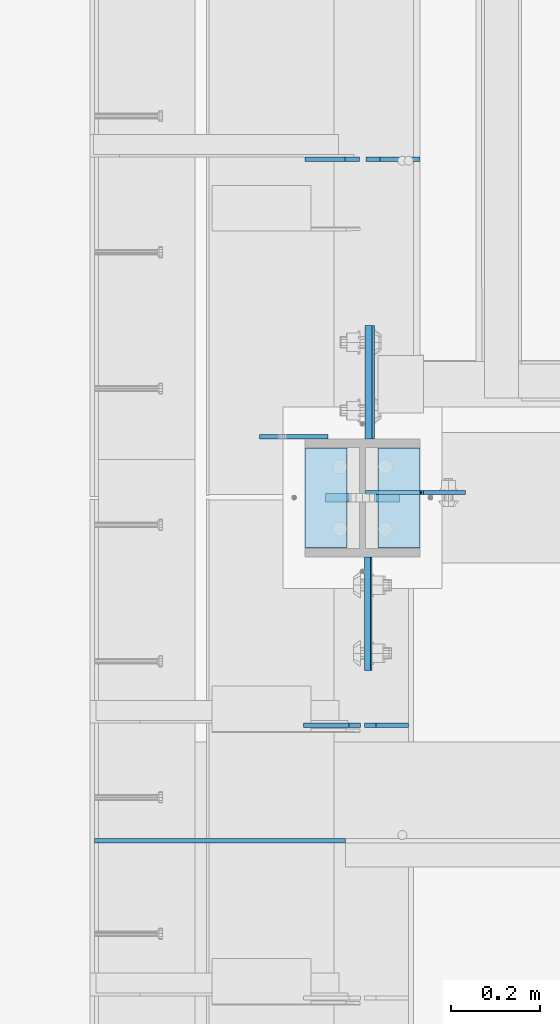
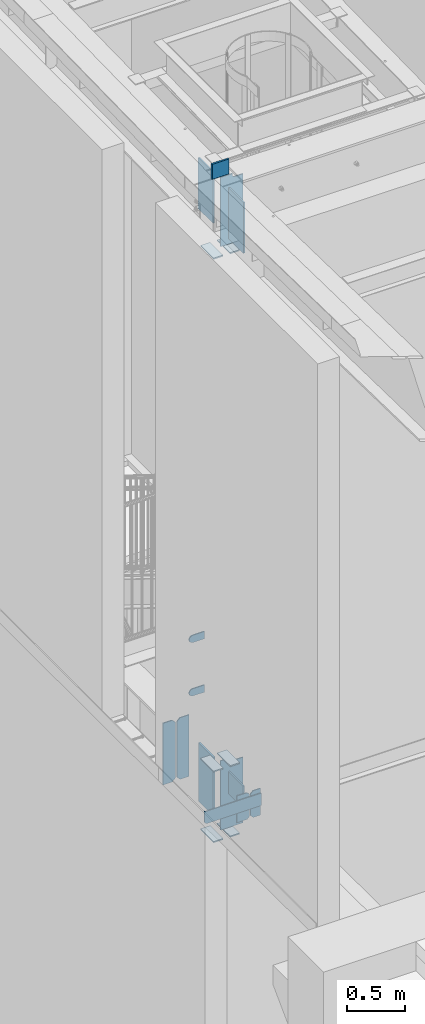
# One storey, part 1505 of 1763: 20 plates, 3 elements without a shape of their own.
"""IFC2X3 building model written with IfcOpenShell, lengths in millimetres."""

from ifc_helpers import new_model, si_unit, frame, origin_with_axes, place, context, subcontext, project, spatial, faceted_brep, material, type_object, element, aggregate, save


model = new_model("IFC2X3")

# Units and contexts
model_context = context("Model", 3, precision=1e-05, world=origin_with_axes())
body_context = subcontext(model_context, "Body", "Model", "MODEL_VIEW")
ifc_project = project(units=[si_unit("LENGTHUNIT", "METRE", prefix="MILLI"), si_unit("AREAUNIT", "SQUARE_METRE"), si_unit("VOLUMEUNIT", "CUBIC_METRE"), si_unit("MASSUNIT", "GRAM", prefix="KILO"), si_unit("TIMEUNIT", "SECOND"), si_unit("PLANEANGLEUNIT", "RADIAN"), si_unit("SOLIDANGLEUNIT", "STERADIAN"), si_unit("THERMODYNAMICTEMPERATUREUNIT", "DEGREE_CELSIUS"), si_unit("LUMINOUSINTENSITYUNIT", "LUMEN")], contexts=[model_context])

# Site, building, storey
site_placement = place(None, origin_with_axes())
site = spatial("IfcSite", under=ifc_project, at=site_placement, CompositionType="ELEMENT")
building_placement = place(site_placement, origin_with_axes())
building = spatial("IfcBuilding", under=site, at=building_placement, Name="Undefined", CompositionType="ELEMENT")
storey_placement = place(building_placement, origin_with_axes())
storey = spatial("IfcBuildingStorey", under=building, at=storey_placement, Name="Undefined", CompositionType="ELEMENT", Elevation=0.0)

# Assembly, plates
assembly_1_placement = place(storey_placement, origin_with_axes())
assembly_1 = element("IfcElementAssembly", 1, at=assembly_1_placement, inside=storey, Name="COLUMN", AssemblyPlace="NOTDEFINED", PredefinedType="RIGID_FRAME")
ifc_material_1 = material(Name="STEEL/A36")
plate_type_1 = type_object("IfcPlateType", PredefinedType="NOTDEFINED")
plate_1_placement = place(assembly_1_placement, frame((-87453.2247736983, 30159.325, 6489.69999847412), z_axis=(0.0, 0.0, -1.0), x_axis=(-1.0, 0.0, 0.0)))
plate_1 = element("IfcPlate", 2, at=plate_1_placement, type_object=plate_type_1, material=ifc_material_1, Name="PLATE", context=body_context, shape_type="Brep", body=[
    faceted_brep([(0.0, -4.76249999999982, 0.0), (0.0, -4.76250000000073, 76.1999969482422), (0.0, 4.76250000000073, 76.1999969482422), (0.0, 4.76249999999982, 0.0), (114.299995422363, -4.76250000000073, 76.1999969482422), (114.299995422363, 4.76250000000073, 76.1999969482422), (126.073542436527, -4.76250000000073, 74.3352502937696), (126.073542436527, 4.76250000000073, 74.3352502937696), (136.694612637817, -4.76250000000073, 68.923544725345), (136.694612637817, 4.76250000000073, 68.923544725345), (145.123541673587, -4.76250000000073, 60.4946156895749), (145.123541673587, 4.76250000000073, 60.4946156895749), (150.535247242013, -4.76250000000073, 49.8735454882844), (150.535247242013, 4.76250000000073, 49.8735454882844), (152.399993896484, -4.76250000000073, 38.0999984741211), (152.399993896484, 4.76250000000073, 38.0999984741211), (150.535247242013, -4.76250000000073, 26.3264514599578), (150.535247242013, 4.76250000000073, 26.3264514599578), (145.123541673587, -4.76250000000073, 15.7053812586673), (145.123541673587, 4.76250000000073, 15.7053812586673), (136.694612637817, -4.76250000000073, 7.27645222289721), (136.694612637817, 4.76250000000073, 7.27645222289721), (126.073542436527, -4.76250000000073, 1.86474665447258), (126.073542436527, 4.76250000000073, 1.86474665447258), (114.299995422363, -4.76250000000073, 0.0), (114.299995422363, 4.76250000000073, 0.0)], [[[0, 1, 2, 3]], [[1, 4, 5, 2]], [[4, 6, 7, 5]], [[6, 8, 9, 7]], [[8, 10, 11, 9]], [[10, 12, 13, 11]], [[12, 14, 15, 13]], [[14, 16, 17, 15]], [[16, 18, 19, 17]], [[18, 20, 21, 19]], [[20, 22, 23, 21]], [[22, 24, 25, 23]], [[24, 0, 3, 25]], [[5, 7, 9, 11, 13, 15, 17, 19, 21, 23, 25, 3, 2]], [[24, 22, 20, 18, 16, 14, 12, 10, 8, 6, 4, 1, 0]]]),
])
plate_2_placement = place(assembly_1_placement, frame((-87453.2247736983, 30159.325, 5930.89999847412), z_axis=(0.0, 0.0, -1.0), x_axis=(-1.0, 0.0, 0.0)))
plate_2 = element("IfcPlate", 3, at=plate_2_placement, type_object=plate_type_1, material=ifc_material_1, Name="PLATE", context=body_context, shape_type="Brep", body=[
    faceted_brep([(0.0, -4.76249999999982, 0.0), (0.0, -4.76250000000073, 76.1999969482422), (0.0, 4.76250000000073, 76.1999969482422), (0.0, 4.76249999999982, 0.0), (114.299995422363, -4.76250000000073, 76.1999969482422), (114.299995422363, 4.76250000000073, 76.1999969482422), (126.073542436527, -4.76250000000073, 74.3352502937696), (126.073542436527, 4.76250000000073, 74.3352502937696), (136.694612637817, -4.76250000000073, 68.923544725345), (136.694612637817, 4.76250000000073, 68.923544725345), (145.123541673587, -4.76250000000073, 60.4946156895749), (145.123541673587, 4.76250000000073, 60.4946156895749), (150.535247242013, -4.76250000000073, 49.8735454882844), (150.535247242013, 4.76250000000073, 49.8735454882844), (152.399993896484, -4.76250000000073, 38.0999984741211), (152.399993896484, 4.76250000000073, 38.0999984741211), (150.535247242013, -4.76250000000073, 26.3264514599578), (150.535247242013, 4.76250000000073, 26.3264514599578), (145.123541673587, -4.76250000000073, 15.7053812586673), (145.123541673587, 4.76250000000073, 15.7053812586673), (136.694612637817, -4.76250000000073, 7.27645222289721), (136.694612637817, 4.76250000000073, 7.27645222289721), (126.073542436527, -4.76250000000073, 1.86474665447258), (126.073542436527, 4.76250000000073, 1.86474665447258), (114.299995422363, -4.76250000000073, 0.0), (114.299995422363, 4.76250000000073, 0.0)], [[[0, 1, 2, 3]], [[1, 4, 5, 2]], [[4, 6, 7, 5]], [[6, 8, 9, 7]], [[8, 10, 11, 9]], [[10, 12, 13, 11]], [[12, 14, 15, 13]], [[14, 16, 17, 15]], [[16, 18, 19, 17]], [[18, 20, 21, 19]], [[20, 22, 23, 21]], [[22, 24, 25, 23]], [[24, 0, 3, 25]], [[5, 7, 9, 11, 13, 15, 17, 19, 21, 23, 25, 3, 2]], [[24, 22, 20, 18, 16, 14, 12, 10, 8, 6, 4, 1, 0]]]),
])

assembly_2_placement = place(storey_placement, origin_with_axes())
assembly_2 = element("IfcElementAssembly", 4, at=assembly_2_placement, inside=storey, Name="BEAM", AssemblyPlace="NOTDEFINED", PredefinedType="RIGID_FRAME")
plate_type_2 = type_object("IfcPlateType", PredefinedType="NOTDEFINED")
plate_3_placement = place(assembly_2_placement, frame((-87975.5122492843, 29256.0374999971, 5203.825), z_axis=(0.0, 0.0, 1.0), x_axis=(1.0, 0.0, 0.0)))
plate_3 = element("IfcPlate", 5, at=plate_3_placement, type_object=plate_type_2, material=ifc_material_1, Name="PLATE", context=body_context, shape_type="Brep", body=[
    faceted_brep([(6.96272763889283e-08, -4.76249999999709, 19.0499992370605), (0.0, -4.76250000000073, 130.175003051758), (0.0, 4.76250000000073, 130.175003051758), (6.96454662829638e-08, 4.76249999999709, 19.0499992370605), (561.974975585938, -4.76250000000073, 130.175003051758), (561.974975585938, 4.76250000000073, 130.175003051758), (561.974975585938, -4.76250000000073, 0.0), (561.974975585938, 4.76250000000073, 0.0), (19.0499992370533, -4.76249999996799, -2.09183781407773e-11), (19.0499992370678, 4.76250000003347, -2.09183781407773e-11)], [[[0, 1, 2, 3]], [[1, 4, 5, 2]], [[4, 6, 7, 5]], [[6, 8, 9, 7]], [[8, 0, 3, 9]], [[5, 7, 9, 3, 2]], [[8, 6, 4, 1, 0]]]),
])
plate_type_3 = type_object("IfcPlateType", PredefinedType="NOTDEFINED")
plate_4_placement = place(assembly_2_placement, frame((-87380.1997736983, 29514.00625, 4899.025), z_axis=(0.0, 0.0, 1.0), x_axis=(-1.0, 0.0, 0.0)))
plate_4 = element("IfcPlate", 6, at=plate_4_placement, type_object=plate_type_3, material=ifc_material_1, Name="PLATE", context=body_context, shape_type="Brep", body=[
    faceted_brep([(0.0, -4.76250000000073, 25.3999996185303), (0.0, -4.76250000000073, 253.999994277954), (0.0, 4.76250000000073, 253.999994277954), (0.0, 4.76250000000073, 25.3999996185303), (25.3999996185303, -4.76250000000073, 279.399993896484), (25.3999996185303, 4.76250000000073, 279.399993896484), (127.0, -4.76250000000073, 279.399993896484), (127.0, 4.76250000000073, 279.399993896484), (127.0, -4.76250000000073, 0.0), (127.0, 4.76250000000073, 0.0), (25.3999996185303, -4.76250000000073, 0.0), (25.3999996185303, 4.76250000000073, 0.0)], [[[0, 1, 2, 3]], [[1, 4, 5, 2]], [[4, 6, 7, 5]], [[6, 8, 9, 7]], [[8, 10, 11, 9]], [[10, 0, 3, 11]], [[5, 7, 9, 11, 3, 2]], [[10, 8, 6, 4, 1, 0]]]),
])
plate_type_4 = type_object("IfcPlateType", PredefinedType="NOTDEFINED")
plate_5_placement = place(assembly_2_placement, frame((-87272.2497736983, 29514.00625, 4899.025), z_axis=(0.0, 0.0, 1.0), x_axis=(-1.0, 0.0, 0.0)))
plate_5 = element("IfcPlate", 7, at=plate_5_placement, type_object=plate_type_4, material=ifc_material_1, Name="PLATE", context=body_context, shape_type="Brep", body=[
    faceted_brep([(0.0, -4.76249999999982, 0.0), (0.0, -4.76250000000073, 279.399993896484), (0.0, 4.76250000000073, 279.399993896484), (0.0, 4.76249999999982, 0.0), (73.0250034332275, -4.76250000000073, 279.399993896484), (73.0250034332275, 4.76250000000073, 279.399993896484), (98.4250030517578, -4.76250000000073, 253.999994277954), (98.4250030517578, 4.76250000000073, 253.999994277954), (98.4250030517578, -4.76250000000073, 25.3999996185303), (98.4250030517578, 4.76250000000073, 25.3999996185303), (73.0250034332275, -4.76250000000073, 0.0), (73.0250034332275, 4.76250000000073, 0.0)], [[[0, 1, 2, 3]], [[1, 4, 5, 2]], [[4, 6, 7, 5]], [[6, 8, 9, 7]], [[8, 10, 11, 9]], [[10, 0, 3, 11]], [[5, 7, 9, 11, 3, 2]], [[10, 8, 6, 4, 1, 0]]]),
])
aggregate(assembly_2, [plate_5, plate_4, plate_3])

assembly_3_placement = place(storey_placement, origin_with_axes())
assembly_3 = element("IfcElementAssembly", 8, at=assembly_3_placement, inside=storey, Name="BEAM", AssemblyPlace="NOTDEFINED", PredefinedType="RIGID_FRAME")
plate_type_5 = type_object("IfcPlateType", PredefinedType="NOTDEFINED")
plate_6_placement = place(assembly_3_placement, frame((-87246.8497736984, 30780.0375, 4525.9625), z_axis=(0.0, 0.0, 1.0), x_axis=(-1.0, 0.0, 0.0)))
plate_6 = element("IfcPlate", 9, at=plate_6_placement, type_object=plate_type_5, material=ifc_material_1, Name="PLATE", context=body_context, shape_type="Brep", body=[
    faceted_brep([(0.0, -4.76249999999982, 0.0), (0.0, -4.76250000000073, 644.525024414062), (0.0, 4.76250000000073, 644.525024414062), (0.0, 4.76249999999982, 0.0), (89.6937484741211, -4.76250000000073, 644.525024414062), (89.6937484741211, 4.76250000000073, 644.525024414062), (121.443748474121, -4.76250000000073, 612.775024414062), (121.443748474121, 4.76250000000073, 612.775024414062), (121.443748474121, -4.76250000000073, 31.75), (121.443748474121, 4.76250000000073, 31.75), (89.6937484741211, -4.76249999999709, 0.0), (89.6937484741211, 4.76249999999709, 0.0)], [[[0, 1, 2, 3]], [[1, 4, 5, 2]], [[4, 6, 7, 5]], [[6, 8, 9, 7]], [[8, 10, 11, 9]], [[10, 0, 3, 11]], [[5, 7, 9, 11, 3, 2]], [[10, 8, 6, 4, 1, 0]]]),
])
plate_7_placement = place(assembly_3_placement, frame((-87382.5810236984, 30780.0375, 4525.9625), z_axis=(0.0, 0.0, 1.0), x_axis=(-1.0, 0.0, 0.0)))
plate_7 = element("IfcPlate", 10, at=plate_7_placement, type_object=plate_type_5, material=ifc_material_1, Name="PLATE", context=body_context, shape_type="Brep", body=[
    faceted_brep([(0.0, -4.76250000000073, 31.75), (0.0, -4.76250000000073, 612.775024414062), (0.0, 4.76250000000073, 612.775024414062), (0.0, 4.76250000000073, 31.75), (31.75, -4.76250000000073, 644.525024414062), (31.75, 4.76250000000073, 644.525024414062), (121.443748474121, -4.76250000000073, 644.525024414062), (121.443748474121, 4.76250000000073, 644.525024414062), (121.443748474121, -4.76250000000073, 0.0), (121.443748474121, 4.76250000000073, 0.0), (31.75, -4.76250000000073, 0.0), (31.75, 4.76250000000073, 0.0)], [[[0, 1, 2, 3]], [[1, 4, 5, 2]], [[4, 6, 7, 5]], [[6, 8, 9, 7]], [[8, 10, 11, 9]], [[10, 0, 3, 11]], [[5, 7, 9, 11, 3, 2]], [[10, 8, 6, 4, 1, 0]]]),
])
aggregate(assembly_3, [plate_6, plate_7])

# Plate
ifc_material_2 = material(Name="STEEL/A572-50")
plate_type_6 = type_object("IfcPlateType", PredefinedType="NOTDEFINED")
plate_8_placement = place(assembly_1_placement, frame((-87292.8872721725, 30022.8000001452, 11455.3999938917), z_axis=(0.0, 0.0, -1.0), x_axis=(-1.0, 0.0, 0.0)))
plate_8 = element("IfcPlate", 11, at=plate_8_placement, type_object=plate_type_6, material=ifc_material_2, Name="PLATE", context=body_context, shape_type="Brep", body=[
    faceted_brep([(7.27595761418343e-12, 9.52500000000146, 155.574990844727), (-1.45519152283669e-11, 7.27595761418343e-12, 165.099990844727), (165.099990844727, 0.0, 165.099990844727), (165.099990844727, 9.52500000000146, 155.574990844727), (-3.63797880709171e-11, -9.5249999999869, 155.574990844727), (165.099990844727, -9.52500000000146, 155.574990844727), (0.0, 9.52500000000146, 0.0), (0.0, -9.52500000000146, 0.0), (165.099990844727, -9.52500000000146, 0.0), (165.099990844727, 9.52500000000146, 0.0)], [[[0, 1, 2, 3]], [[1, 4, 5, 2]], [[6, 7, 4, 1, 0]], [[5, 8, 9, 3, 2]], [[8, 7, 6, 9]], [[9, 6, 0, 3]], [[7, 8, 5, 4]]]),
])

plate_type_7 = type_object("IfcPlateType", PredefinedType="NOTDEFINED")
plate_9_placement = place(assembly_1_placement, frame((-87410.3622736983, 29911.675, 10547.2838431128), z_axis=(0.0, 1.0, 0.0), x_axis=(-1.0, 0.0, 0.0)))
plate_9 = element("IfcPlate", 12, at=plate_9_placement, type_object=plate_type_7, material=ifc_material_1, Name="PLATE", context=body_context, shape_type="Brep", body=[
    faceted_brep([(0.0, -6.34999999999491, 1.45519152283669e-11), (0.0, -6.35000000000036, 222.25), (0.0, 6.35000000000036, 222.25), (0.0, 6.34999999999491, -2.91038304567337e-11), (93.6624984741211, -6.35000000000036, 222.25), (93.6624984741211, 6.35000000000036, 222.25), (93.6624984741211, -6.35000000000036, 0.0), (93.6624984741211, 6.35000000000036, 0.0)], [[[0, 1, 2, 3]], [[1, 4, 5, 2]], [[4, 6, 7, 5]], [[6, 0, 3, 7]], [[5, 7, 3, 2]], [[6, 4, 1, 0]]]),
])

plate_10_placement = place(assembly_1_placement, frame((-87410.3622736983, 29911.675, 4451.34997558594), z_axis=(0.0, 1.0, 0.0), x_axis=(-1.0, 0.0, 0.0)))
plate_10 = element("IfcPlate", 13, at=plate_10_placement, type_object=plate_type_7, material=ifc_material_1, Name="PLATE", context=body_context, shape_type="Brep", body=[
    faceted_brep([(0.0, -6.34999999999491, 1.45519152283669e-11), (0.0, -6.35000000000036, 222.25), (0.0, 6.35000000000036, 222.25), (0.0, 6.34999999999491, -2.91038304567337e-11), (93.6624984741211, -6.35000000000036, 222.25), (93.6624984741211, 6.35000000000036, 222.25), (93.6624984741211, -6.35000000000036, 0.0), (93.6624984741211, 6.35000000000036, 0.0)], [[[0, 1, 2, 3]], [[1, 4, 5, 2]], [[4, 6, 7, 5]], [[6, 0, 3, 7]], [[5, 7, 3, 2]], [[6, 4, 1, 0]]]),
])

plate_11_placement = place(assembly_1_placement, frame((-87410.3622736983, 29911.675, 5187.95), z_axis=(0.0, 1.0, 0.0), x_axis=(-1.0, 0.0, 0.0)))
plate_11 = element("IfcPlate", 14, at=plate_11_placement, type_object=plate_type_7, material=ifc_material_1, Name="PLATE", context=body_context, shape_type="Brep", body=[
    faceted_brep([(0.0, -6.34999999999491, 1.45519152283669e-11), (0.0, -6.35000000000036, 222.25), (0.0, 6.35000000000036, 222.25), (0.0, 6.34999999999491, -2.91038304567337e-11), (93.6624984741211, -6.35000000000036, 222.25), (93.6624984741211, 6.35000000000036, 222.25), (93.6624984741211, -6.35000000000036, 0.0), (93.6624984741211, 6.35000000000036, 0.0)], [[[0, 1, 2, 3]], [[1, 4, 5, 2]], [[4, 6, 7, 5]], [[6, 0, 3, 7]], [[5, 7, 3, 2]], [[6, 4, 1, 0]]]),
])

plate_12_placement = place(assembly_1_placement, frame((-87246.8497736983, 29911.675, 10547.2838431128), z_axis=(0.0, 1.0, 0.0), x_axis=(-1.0, 0.0, 0.0)))
plate_12 = element("IfcPlate", 15, at=plate_12_placement, type_object=plate_type_7, material=ifc_material_1, Name="PLATE", context=body_context, shape_type="Brep", body=[
    faceted_brep([(0.0, -6.34999999999491, 1.45519152283669e-11), (0.0, -6.35000000000036, 222.25), (0.0, 6.35000000000036, 222.25), (0.0, 6.34999999999491, -2.91038304567337e-11), (93.6624984741211, -6.35000000000036, 222.25), (93.6624984741211, 6.35000000000036, 222.25), (93.6624984741211, -6.35000000000036, 0.0), (93.6624984741211, 6.35000000000036, 0.0)], [[[0, 1, 2, 3]], [[1, 4, 5, 2]], [[4, 6, 7, 5]], [[6, 0, 3, 7]], [[5, 7, 3, 2]], [[6, 4, 1, 0]]]),
])

plate_13_placement = place(assembly_1_placement, frame((-87246.8497736983, 29911.675, 4451.34997558594), z_axis=(0.0, 1.0, 0.0), x_axis=(-1.0, 0.0, 0.0)))
plate_13 = element("IfcPlate", 16, at=plate_13_placement, type_object=plate_type_7, material=ifc_material_1, Name="PLATE", context=body_context, shape_type="Brep", body=[
    faceted_brep([(0.0, -6.34999999999491, 1.45519152283669e-11), (0.0, -6.35000000000036, 222.25), (0.0, 6.35000000000036, 222.25), (0.0, 6.34999999999491, -2.91038304567337e-11), (93.6624984741211, -6.35000000000036, 222.25), (93.6624984741211, 6.35000000000036, 222.25), (93.6624984741211, -6.35000000000036, 0.0), (93.6624984741211, 6.35000000000036, 0.0)], [[[0, 1, 2, 3]], [[1, 4, 5, 2]], [[4, 6, 7, 5]], [[6, 0, 3, 7]], [[5, 7, 3, 2]], [[6, 4, 1, 0]]]),
])

plate_14_placement = place(assembly_1_placement, frame((-87246.8497736983, 29911.675, 5187.95), z_axis=(0.0, 1.0, 0.0), x_axis=(-1.0, 0.0, 0.0)))
plate_14 = element("IfcPlate", 17, at=plate_14_placement, type_object=plate_type_7, material=ifc_material_1, Name="PLATE", context=body_context, shape_type="Brep", body=[
    faceted_brep([(0.0, -6.34999999999491, 1.45519152283669e-11), (0.0, -6.35000000000036, 222.25), (0.0, 6.35000000000036, 222.25), (0.0, 6.34999999999491, -2.91038304567337e-11), (93.6624984741211, -6.35000000000036, 222.25), (93.6624984741211, 6.35000000000036, 222.25), (93.6624984741211, -6.35000000000036, 0.0), (93.6624984741211, 6.35000000000036, 0.0)], [[[0, 1, 2, 3]], [[1, 4, 5, 2]], [[4, 6, 7, 5]], [[6, 0, 3, 7]], [[5, 7, 3, 2]], [[6, 4, 1, 0]]]),
])

plate_type_8 = type_object("IfcPlateType", PredefinedType="NOTDEFINED")
plate_15_placement = place(assembly_1_placement, frame((-87358.7685236984, 30154.5625, 5143.5), z_axis=(0.0, 1.0, 0.0), x_axis=(0.0, 0.0, -1.0)))
plate_15 = element("IfcPlate", 18, at=plate_15_placement, type_object=plate_type_8, material=ifc_material_2, Name="PLATE", context=body_context, shape_type="Brep", body=[
    faceted_brep([(0.0, -9.52500000000146, 0.0), (1.13504938781261e-09, -9.52499999999964, 254.000000000065), (1.13504938781261e-09, 9.52499999999964, 254.000000000065), (0.0, 9.52500000000146, 0.0), (609.599975585938, -9.52499999999418, 254.0), (609.599975585938, 9.52499999999418, 254.0), (609.599975585938, -9.52499999999418, 0.0), (609.599975585938, 9.52499999999418, 0.0)], [[[0, 1, 2, 3]], [[1, 4, 5, 2]], [[4, 6, 7, 5]], [[6, 0, 3, 7]], [[5, 7, 3, 2]], [[6, 4, 1, 0]]]),
])

plate_type_9 = type_object("IfcPlateType", PredefinedType="NOTDEFINED")
plate_16_placement = place(assembly_1_placement, frame((-87364.3247736983, 29891.0375, 5156.2), z_axis=(0.0, -1.0, 0.0), x_axis=(0.0, 0.0, -1.0)))
plate_16 = element("IfcPlate", 19, at=plate_16_placement, type_object=plate_type_9, material=ifc_material_2, Name="PLATE", context=body_context, shape_type="Brep", body=[
    faceted_brep([(0.0, -6.34999999999491, 1.45519152283669e-11), (0.0, -6.34999999999854, 254.0), (0.0, 6.34999999999854, 254.0), (0.0, 6.34999999999491, -2.91038304567337e-11), (228.600006103516, -6.34999999999854, 254.0), (228.600006103516, 6.34999999999854, 254.0), (228.600006103565, -6.34999999936554, -7.49423634260893e-10), (228.600006103557, 6.35000000064611, -7.13043846189976e-10)], [[[0, 1, 2, 3]], [[1, 4, 5, 2]], [[4, 6, 7, 5]], [[6, 0, 3, 7]], [[5, 7, 3, 2]], [[6, 4, 1, 0]]]),
])

plate_type_10 = type_object("IfcPlateType", PredefinedType="NOTDEFINED")
plate_17_placement = place(assembly_1_placement, frame((-87361.9435236984, 29891.0375, 11256.2641107601), z_axis=(0.0, -1.0, 0.0), x_axis=(0.0, 0.0, -1.0)))
plate_17 = element("IfcPlate", 20, at=plate_17_placement, type_object=plate_type_10, material=ifc_material_2, Name="PLATE", context=body_context, shape_type="Brep", body=[
    faceted_brep([(-7.27595761418343e-12, -7.9375, 0.0), (0.0, -7.9375, 254.0), (0.0, 7.9375, 254.0), (-7.27595761418343e-12, 7.9375, 0.0), (533.400024414062, -7.9375, 254.0), (533.400024414062, 7.9375, 254.0), (533.400024414062, -7.9375, 0.0), (533.400024414062, 7.9375, 0.0)], [[[0, 1, 2, 3]], [[1, 4, 5, 2]], [[4, 6, 7, 5]], [[6, 0, 3, 7]], [[5, 7, 3, 2]], [[6, 4, 1, 0]]]),
])

plate_18_placement = place(assembly_1_placement, frame((-87361.9435236984, 30154.5624999999, 11256.2236063034), z_axis=(0.0, 1.0, 0.0), x_axis=(0.0, 0.0, -1.0)))
plate_18 = element("IfcPlate", 21, at=plate_18_placement, type_object=plate_type_10, material=ifc_material_2, Name="PLATE", context=body_context, shape_type="Brep", body=[
    faceted_brep([(-7.27595761418343e-12, -7.9375, 0.0), (0.0, -7.9375, 254.0), (0.0, 7.9375, 254.0), (-7.27595761418343e-12, 7.9375, 0.0), (533.400024414062, -7.9375, 254.0), (533.400024414062, 7.9375, 254.0), (533.400024414062, -7.9375, 0.0), (533.400024414062, 7.9375, 0.0)], [[[0, 1, 2, 3]], [[1, 4, 5, 2]], [[4, 6, 7, 5]], [[6, 0, 3, 7]], [[5, 7, 3, 2]], [[6, 4, 1, 0]]]),
])

plate_type_11 = type_object("IfcPlateType", PredefinedType="NOTDEFINED")
plate_19_placement = place(assembly_1_placement, frame((-87369.0872736983, 30034.7062498557, 11277.5338675269), z_axis=(1.0, 0.0, 0.0), x_axis=(0.0, 0.0, -1.0)))
plate_19 = element("IfcPlate", 22, at=plate_19_placement, type_object=plate_type_11, material=ifc_material_1, Name="PLATE", context=body_context, shape_type="Brep", body=[
    faceted_brep([(25.4000001907334, -4.76250000000073, 122.237503051758), (25.4000001907334, 4.76250000000073, 122.237503051758), (-2.5465851649642e-11, 4.76250000019581, 122.237500000236), (-3.45607986673713e-11, -4.76249999983202, 122.23750000025), (30.2600797087798, -4.76250000000073, 123.204232974349), (30.2600797087798, 4.76250000000073, 123.204232974349), (34.3802561769335, -4.76250000000073, 125.957246874823), (34.3802561769335, 4.76250000000073, 125.957246874823), (37.133270077411, -4.76250000000073, 130.077423342977), (37.133270077411, 4.76250000000073, 130.077423342977), (38.0999999999985, -4.76250000000073, 134.937502861023), (38.0999999999985, 4.76250000000073, 134.937502861023), (38.0999999999985, -4.76250000000073, 223.837493896484), (38.0999999999985, 4.76250000000073, 223.837493896484), (723.900024414062, -4.76250000000073, 0.0), (0.0, -4.76249999999982, 0.0), (0.0, 4.76249999999982, 0.0), (723.900024414062, 4.76250000000073, 0.0), (723.900024414062, -4.76250000000073, 223.837493896484), (723.900024414062, 4.76250000000073, 223.837493896484)], [[[0, 1, 2, 3]], [[4, 5, 1, 0]], [[6, 7, 5, 4]], [[8, 9, 7, 6]], [[10, 11, 9, 8]], [[12, 13, 11, 10]], [[14, 15, 16, 17]], [[18, 14, 17, 19]], [[8, 6, 4, 0, 3, 15, 14, 18, 12, 10]], [[16, 15, 3, 2]], [[19, 17, 16, 2, 1, 5, 7, 9, 11, 13]], [[18, 19, 13, 12]]]),
])

plate_20_placement = place(assembly_1_placement, frame((-87369.0872736983, 30034.70625, 5181.6), z_axis=(1.0, 0.0, 0.0), x_axis=(0.0, 0.0, -1.0)))
plate_20 = element("IfcPlate", 23, at=plate_20_placement, type_object=plate_type_11, material=ifc_material_1, Name="PLATE", context=body_context, shape_type="Brep", body=[
    faceted_brep([(25.4000001907334, -4.76250000000073, 122.237503051758), (25.4000001907334, 4.76250000000073, 122.237503051758), (-2.5465851649642e-11, 4.76250000019581, 122.237500000236), (-3.45607986673713e-11, -4.76249999983202, 122.23750000025), (30.2600797087798, -4.76250000000073, 123.204232974349), (30.2600797087798, 4.76250000000073, 123.204232974349), (34.3802561769335, -4.76250000000073, 125.957246874823), (34.3802561769335, 4.76250000000073, 125.957246874823), (37.133270077411, -4.76250000000073, 130.077423342977), (37.133270077411, 4.76250000000073, 130.077423342977), (38.0999999999985, -4.76250000000073, 134.937502861023), (38.0999999999985, 4.76250000000073, 134.937502861023), (38.0999999999985, -4.76250000000073, 223.837493896484), (38.0999999999985, 4.76250000000073, 223.837493896484), (723.900024414062, -4.76250000000073, 0.0), (0.0, -4.76249999999982, 0.0), (0.0, 4.76249999999982, 0.0), (723.900024414062, 4.76250000000073, 0.0), (723.900024414062, -4.76250000000073, 223.837493896484), (723.900024414062, 4.76250000000073, 223.837493896484)], [[[0, 1, 2, 3]], [[4, 5, 1, 0]], [[6, 7, 5, 4]], [[8, 9, 7, 6]], [[10, 11, 9, 8]], [[12, 13, 11, 10]], [[14, 15, 16, 17]], [[18, 14, 17, 19]], [[8, 6, 4, 0, 3, 15, 14, 18, 12, 10]], [[16, 15, 3, 2]], [[19, 17, 16, 2, 1, 5, 7, 9, 11, 13]], [[18, 19, 13, 12]]]),
])

aggregate(assembly_1, [plate_1, plate_2, plate_8, plate_9, plate_10, plate_11, plate_12, plate_19, plate_17, plate_18, plate_13, plate_14, plate_20, plate_16, plate_15])

save(model, "model.ifc")
